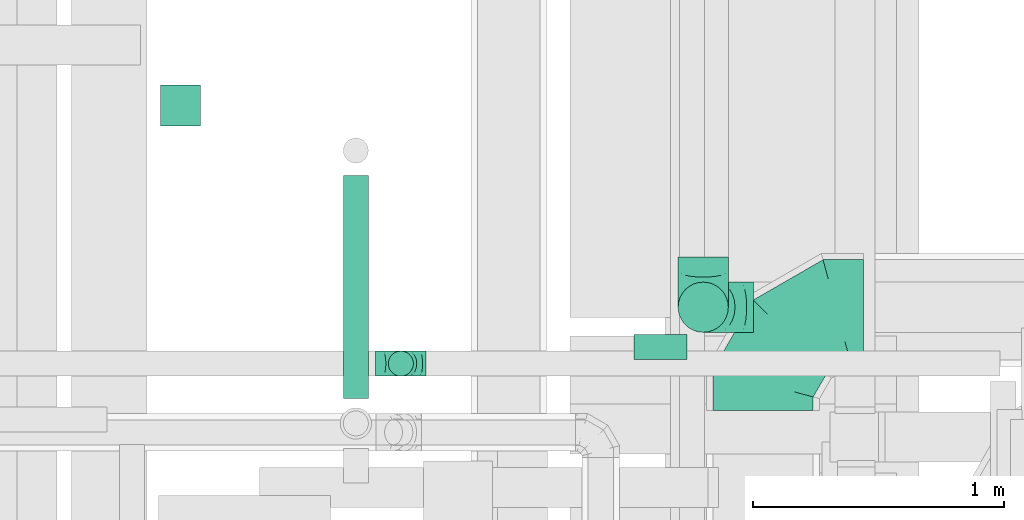
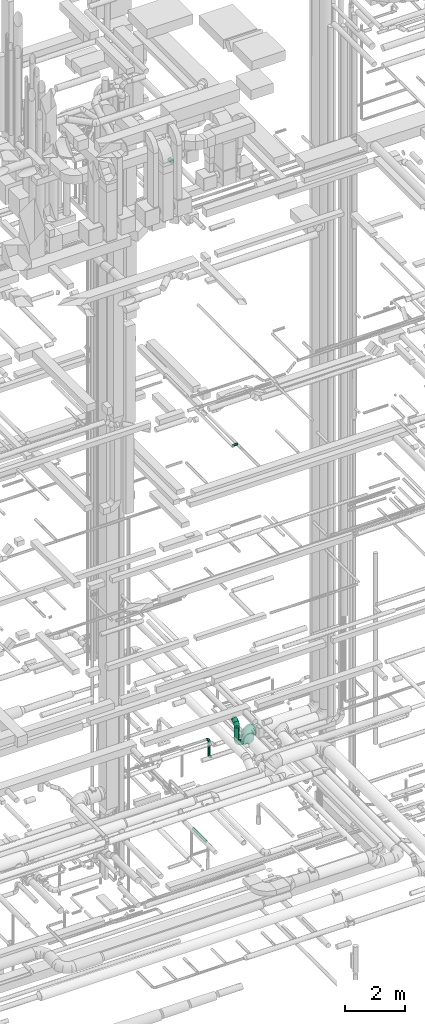
# One storey, part 267 of 337: 5 flow fittings, 5 flow segments.
"""IFC2X3 building model written with IfcOpenShell, lengths in millimetres."""

from ifc_helpers import new_model, entity, si_unit, converted_unit, derived_unit, direction, frame, origin, origin_2d_with_axis, place, context, subcontext, project, spatial, circle, extrude, faceted_brep, source, transform, mapped, material, type_object, type_shapes, element, save


model = new_model("IFC2X3")

# Units and contexts
model_context = context("Model", 3, precision=0.01, world=origin(), true_north=direction((6.12303176911189e-17, 1.0)))
body_context = subcontext(model_context, "Body", "Model", "MODEL_VIEW")
ifc_project = project(units=[si_unit("LENGTHUNIT", "METRE", prefix="MILLI"), si_unit("AREAUNIT", "SQUARE_METRE"), si_unit("VOLUMEUNIT", "CUBIC_METRE"), converted_unit("PLANEANGLEUNIT", "DEGREE", entity("IfcRatioMeasure", 0.0174532925199433), si_unit("PLANEANGLEUNIT", "RADIAN"), dimensions=[0, 0, 0, 0, 0, 0, 0]), si_unit("MASSUNIT", "GRAM", prefix="KILO"), derived_unit("MASSDENSITYUNIT", [(si_unit("MASSUNIT", "GRAM", prefix="KILO"), 1), (si_unit("LENGTHUNIT", "METRE"), -3)]), derived_unit("MOMENTOFINERTIAUNIT", [(si_unit("LENGTHUNIT", "METRE"), 4)]), si_unit("TIMEUNIT", "SECOND"), si_unit("FREQUENCYUNIT", "HERTZ"), si_unit("THERMODYNAMICTEMPERATUREUNIT", "DEGREE_CELSIUS"), derived_unit("THERMALTRANSMITTANCEUNIT", [(si_unit("MASSUNIT", "GRAM", prefix="KILO"), 1), (si_unit("THERMODYNAMICTEMPERATUREUNIT", "KELVIN"), -1), (si_unit("TIMEUNIT", "SECOND"), -3)]), derived_unit("VOLUMETRICFLOWRATEUNIT", [(si_unit("LENGTHUNIT", "METRE"), 3), (si_unit("TIMEUNIT", "SECOND"), -1)]), derived_unit("MASSFLOWRATEUNIT", [(si_unit("MASSUNIT", "GRAM", prefix="KILO"), 1), (si_unit("TIMEUNIT", "SECOND"), -1)]), derived_unit("ROTATIONALFREQUENCYUNIT", [(si_unit("TIMEUNIT", "SECOND"), -1)]), si_unit("ELECTRICCURRENTUNIT", "AMPERE"), si_unit("ELECTRICVOLTAGEUNIT", "VOLT"), si_unit("POWERUNIT", "WATT"), si_unit("FORCEUNIT", "NEWTON", prefix="KILO"), si_unit("ILLUMINANCEUNIT", "LUX"), si_unit("LUMINOUSFLUXUNIT", "LUMEN"), si_unit("LUMINOUSINTENSITYUNIT", "CANDELA"), derived_unit("USERDEFINED", [(si_unit("MASSUNIT", "GRAM", prefix="KILO"), -1), (si_unit("LENGTHUNIT", "METRE"), -2), (si_unit("TIMEUNIT", "SECOND"), 3), (si_unit("LUMINOUSFLUXUNIT", "LUMEN"), 1)]), derived_unit("LINEARVELOCITYUNIT", [(si_unit("LENGTHUNIT", "METRE"), 1), (si_unit("TIMEUNIT", "SECOND"), -1)]), si_unit("PRESSUREUNIT", "PASCAL"), derived_unit("USERDEFINED", [(si_unit("LENGTHUNIT", "METRE"), -2), (si_unit("MASSUNIT", "GRAM", prefix="KILO"), 1), (si_unit("TIMEUNIT", "SECOND"), -2)]), derived_unit("LINEARFORCEUNIT", [(si_unit("MASSUNIT", "GRAM", prefix="KILO"), 1), (si_unit("LENGTHUNIT", "METRE"), 1), (si_unit("TIMEUNIT", "SECOND"), -2), (si_unit("LENGTHUNIT", "METRE"), -1)]), derived_unit("PLANARFORCEUNIT", [(si_unit("MASSUNIT", "GRAM", prefix="KILO"), 1), (si_unit("LENGTHUNIT", "METRE"), 1), (si_unit("TIMEUNIT", "SECOND"), -2), (si_unit("LENGTHUNIT", "METRE"), -2)])], contexts=[model_context])

# Site, building, storey
site_placement = place(None, origin())
site = spatial("IfcSite", under=ifc_project, at=site_placement, CompositionType="ELEMENT")
building_placement = place(site_placement, origin())
building = spatial("IfcBuilding", under=site, at=building_placement, CompositionType="ELEMENT")
storey_placement = place(building_placement, origin())
storey = spatial("IfcBuildingStorey", under=building, at=storey_placement, CompositionType="ELEMENT", Elevation=0.0)

# Flow segments
duct_segment_type = type_object("IfcDuctSegmentType", PredefinedType="NOTDEFINED")
flow_segment_1_placement = place(storey_placement, frame((62974.94, 11897.88, -651.6)))
element("IfcFlowSegment", 1, at=flow_segment_1_placement, inside=storey, type_object=duct_segment_type, context=body_context, shape_type="SweptSolid", body=[
    extrude(circle(Radius=50.0, at=origin_2d_with_axis()), frame((51.6, 0.0, 51.6), z_axis=(0.0, 1.0, 0.0), x_axis=(1.0, 0.0, 0.0)), (0.0, 0.0, 1.0), 886.783699999998),
])
flow_segment_2_placement = place(storey_placement, frame((64135.03, 12051.29, 14998.4)))
element("IfcFlowSegment", 2, at=flow_segment_2_placement, inside=storey, type_object=duct_segment_type, context=body_context, shape_type="SweptSolid", body=[
    extrude(circle(Radius=50.0, at=origin_2d_with_axis()), frame((0.0, 51.6, 51.6), z_axis=(1.0, 0.0, 0.0), x_axis=(0.0, 1.0, 0.0)), (0.0, 0.0, 1.0), 209.999999999987),
])
flow_segment_3_placement = place(storey_placement, frame((62247.25, 12983.12, 26668.4)))
element("IfcFlowSegment", 3, at=flow_segment_3_placement, inside=storey, type_object=duct_segment_type, context=body_context, shape_type="SweptSolid", body=[
    extrude(circle(Radius=80.0, at=origin_2d_with_axis()), frame((81.6, 0.0, 81.6), z_axis=(0.0, 1.0, 0.0), x_axis=(-1.0, 0.0, 0.0)), (0.0, 0.0, 1.0), 162.499999999996),
])
flow_segment_4_placement = place(storey_placement, frame((64308.55, 12159.21, 2900.0)))
element("IfcFlowSegment", 4, at=flow_segment_4_placement, inside=storey, type_object=duct_segment_type, context=body_context, shape_type="SweptSolid", body=[
    extrude(circle(Radius=100.0, at=origin_2d_with_axis()), frame((101.6, 101.6, 0.0), z_axis=(0.0, 0.0, 1.0), x_axis=(0.0, -1.0, 0.0)), (0.0, 0.0, 1.0), 500.000000000008),
])
flow_segment_5_placement = place(storey_placement, frame((63154.26, 11984.54, 2800.0)))
element("IfcFlowSegment", 5, at=flow_segment_5_placement, inside=storey, type_object=duct_segment_type, context=body_context, shape_type="SweptSolid", body=[
    extrude(circle(Radius=50.0, at=origin_2d_with_axis()), frame((51.6, 51.6, 0.0), z_axis=(0.0, 0.0, 1.0), x_axis=(0.0, 1.0, 0.0)), (0.0, 0.0, 1.0), 549.99999999997),
])

# Flow fittings
ifc_material = material()
duct_fitting_type_1 = type_object("IfcDuctFittingType", PredefinedType="NOTDEFINED", material=ifc_material)
shared_shape_1 = source(origin(), body_context, "Body", "Brep", [
    faceted_brep([(-100.0, 0.0, -50.0), (-100.0, -12.94, -48.3), (-100.0, -25.0, -43.3), (-100.0, -35.36, -35.36), (-100.0, -43.3, -25.0), (-100.0, -48.3, -12.94), (-100.0, -50.0, 0.0), (-100.0, -48.3, 12.94), (-100.0, -43.3, 25.0), (-100.0, -35.36, 35.36), (-100.0, -25.0, 43.3), (-100.0, -12.94, 48.3), (-100.0, 0.0, 50.0), (-100.0, 12.94, 48.3), (-100.0, 25.0, 43.3), (-100.0, 35.36, 35.36), (-100.0, 43.3, 25.0), (-100.0, 48.3, 12.94), (-100.0, 50.0, 0.0), (-100.0, 48.3, -12.94), (-100.0, 43.3, -25.0), (-100.0, 35.36, -35.36), (-100.0, 25.0, -43.3), (-100.0, 12.94, -48.3), (-76.67, 12.94, 48.3), (-79.9, 25.0, 43.3), (-73.21, 0.0, 50.0), (-82.68, 35.36, 35.36), (-86.15, 48.3, 12.94), (-86.6, 50.0, 0.0), (-84.81, 43.3, 25.0), (-84.81, 43.3, -25.0), (-82.68, 35.36, -35.36), (-86.15, 48.3, -12.94), (-76.67, 12.94, -48.3), (-73.21, 0.0, -50.0), (-79.9, 25.0, -43.3), (-69.74, -12.94, -48.3), (-66.51, -25.0, -43.3), (-63.73, -35.36, -35.36), (-61.6, -43.3, -25.0), (-60.26, -48.3, -12.94), (-59.81, -50.0, 0.0), (-60.26, -48.3, 12.94), (-61.6, -43.3, 25.0), (-63.73, -35.36, 35.36), (-66.51, -25.0, 43.3), (-69.74, -12.94, 48.3), (-36.27, 36.27, 48.3), (-45.1, 45.1, 43.3), (-26.79, 26.79, 50.0), (-52.68, 52.68, 35.36), (-58.49, 58.49, 25.0), (-62.15, 62.15, 12.94), (-63.4, 63.4, 0.0), (-62.15, 62.15, -12.94), (-58.49, 58.49, -25.0), (-52.68, 52.68, -35.36), (-36.27, 36.27, -48.3), (-26.79, 26.79, -50.0), (-45.1, 45.1, -43.3), (-17.32, 17.32, -48.3), (-8.49, 8.49, -43.3), (-0.91, 0.91, -35.36), (4.9, -4.9, -25.0), (8.56, -8.56, -12.94), (9.81, -9.81, 0.0), (8.56, -8.56, 12.94), (4.9, -4.9, 25.0), (-0.91, 0.91, 35.36), (-8.49, 8.49, 43.3), (-17.32, 17.32, 48.3), (-12.94, 76.67, 48.3), (-25.0, 79.9, 43.3), (0.0, 73.21, 50.0), (-35.36, 82.68, 35.36), (-43.3, 84.81, 25.0), (-48.3, 86.15, 12.94), (-50.0, 86.6, 0.0), (-48.3, 86.15, -12.94), (-43.3, 84.81, -25.0), (-35.36, 82.68, -35.36), (-12.94, 76.67, -48.3), (0.0, 73.21, -50.0), (-25.0, 79.9, -43.3), (12.94, 69.74, -48.3), (25.0, 66.51, -43.3), (35.36, 63.73, -35.36), (43.3, 61.6, -25.0), (48.3, 60.26, -12.94), (50.0, 59.81, 0.0), (48.3, 60.26, 12.94), (43.3, 61.6, 25.0), (35.36, 63.73, 35.36), (25.0, 66.51, 43.3), (12.94, 69.74, 48.3), (-12.94, 100.0, -48.3), (-25.0, 100.0, -43.3), (-35.36, 100.0, -35.36), (-43.3, 100.0, -25.0), (-48.3, 100.0, -12.94), (-50.0, 100.0, 0.0), (-48.3, 100.0, 12.94), (-43.3, 100.0, 25.0), (-35.36, 100.0, 35.36), (-25.0, 100.0, 43.3), (-12.94, 100.0, 48.3), (0.0, 100.0, 50.0), (12.94, 100.0, 48.3), (25.0, 100.0, 43.3), (35.36, 100.0, 35.36), (43.3, 100.0, 25.0), (48.3, 100.0, 12.94), (50.0, 100.0, 0.0), (48.3, 100.0, -12.94), (43.3, 100.0, -25.0), (35.36, 100.0, -35.36), (25.0, 100.0, -43.3), (12.94, 100.0, -48.3), (0.0, 100.0, -50.0)], [[[0, 1, 2, 3, 4, 5, 6, 7, 8, 9, 10, 11, 12, 13, 14, 15, 16, 17, 18, 19, 20, 21, 22, 23]], [[24, 25, 14, 13]], [[26, 24, 13, 12]], [[14, 25, 27, 15]], [[28, 29, 18, 17]], [[30, 28, 17, 16]], [[15, 27, 30, 16]], [[20, 31, 32, 21]], [[33, 31, 20, 19]], [[18, 29, 33, 19]], [[34, 35, 0, 23]], [[36, 34, 23, 22]], [[32, 36, 22, 21]], [[2, 1, 37, 38]], [[3, 2, 38, 39]], [[0, 35, 37, 1]], [[5, 4, 40, 41]], [[6, 5, 41, 42]], [[3, 39, 40, 4]], [[6, 42, 43, 7]], [[7, 43, 44, 8]], [[8, 44, 45, 9]], [[10, 46, 47, 11]], [[11, 47, 26, 12]], [[10, 9, 45, 46]], [[48, 49, 25, 24]], [[50, 48, 24, 26]], [[27, 25, 49, 51]], [[52, 53, 28, 30]], [[51, 52, 30, 27]], [[29, 28, 53, 54]], [[55, 56, 31, 33]], [[54, 55, 33, 29]], [[57, 32, 31, 56]], [[58, 59, 35, 34]], [[60, 58, 34, 36]], [[57, 60, 36, 32]], [[37, 35, 59, 61]], [[38, 37, 61, 62]], [[39, 38, 62, 63]], [[41, 40, 64, 65]], [[42, 41, 65, 66]], [[63, 64, 40, 39]], [[43, 42, 66, 67]], [[44, 43, 67, 68]], [[68, 69, 45, 44]], [[46, 45, 69, 70]], [[47, 46, 70, 71]], [[26, 47, 71, 50]], [[72, 73, 49, 48]], [[74, 72, 48, 50]], [[51, 49, 73, 75]], [[76, 77, 53, 52]], [[75, 76, 52, 51]], [[54, 53, 77, 78]], [[79, 80, 56, 55]], [[78, 79, 55, 54]], [[81, 57, 56, 80]], [[82, 83, 59, 58]], [[84, 82, 58, 60]], [[81, 84, 60, 57]], [[61, 59, 83, 85]], [[62, 61, 85, 86]], [[63, 62, 86, 87]], [[65, 64, 88, 89]], [[66, 65, 89, 90]], [[87, 88, 64, 63]], [[67, 66, 90, 91]], [[68, 67, 91, 92]], [[92, 93, 69, 68]], [[70, 69, 93, 94]], [[71, 70, 94, 95]], [[50, 71, 95, 74]], [[96, 97, 98, 99, 100, 101, 102, 103, 104, 105, 106, 107, 108, 109, 110, 111, 112, 113, 114, 115, 116, 117, 118, 119]], [[72, 74, 107, 106]], [[73, 72, 106, 105]], [[75, 73, 105, 104]], [[77, 76, 103, 102]], [[78, 77, 102, 101]], [[75, 104, 103, 76]], [[78, 101, 100, 79]], [[79, 100, 99, 80]], [[80, 99, 98, 81]], [[96, 119, 83, 82]], [[97, 96, 82, 84]], [[84, 81, 98, 97]], [[83, 119, 118, 85]], [[85, 118, 117, 86]], [[86, 117, 116, 87]], [[88, 115, 114, 89]], [[89, 114, 113, 90]], [[87, 116, 115, 88]], [[91, 90, 113, 112]], [[92, 91, 112, 111]], [[93, 92, 111, 110]], [[95, 94, 109, 108]], [[74, 95, 108, 107]], [[110, 109, 94, 93]]]),
])
type_shapes(duct_fitting_type_1, [shared_shape_1])
for number, where, z_axis, x_axis in (
    (6, (63205.86, 12036.14, 3450.0), (0.0, 1.0, 0.0), (1.0, 0.0, 0.0)),
    (7, (63205.86, 12036.14, 2700.0), (0.0, -1.0, 0.0), (0.0, 0.0, -1.0)),
):
    element("IfcFlowFitting", number, at=place(storey_placement, frame(where, z_axis=z_axis, x_axis=x_axis)), inside=storey, type_object=duct_fitting_type_1, material=ifc_material, context=body_context, shape_type="MappedRepresentation", body=[
        mapped(shared_shape_1, transform((0.0, 0.0, 0.0), scale=1.0)),
    ])
duct_fitting_type_2 = type_object("IfcDuctFittingType", PredefinedType="NOTDEFINED", material=ifc_material)
shared_shape_2 = source(origin(), body_context, "Body", "Brep", [
    faceted_brep([(-200.0, 0.0, -100.0), (-200.0, -25.88, -96.59), (-200.0, -50.0, -86.6), (-200.0, -70.71, -70.71), (-200.0, -86.6, -50.0), (-200.0, -96.59, -25.88), (-200.0, -100.0, 0.0), (-200.0, -96.59, 25.88), (-200.0, -86.6, 50.0), (-200.0, -70.71, 70.71), (-200.0, -50.0, 86.6), (-200.0, -25.88, 96.59), (-200.0, 0.0, 100.0), (-200.0, 25.88, 96.59), (-200.0, 50.0, 86.6), (-200.0, 70.71, 70.71), (-200.0, 86.6, 50.0), (-200.0, 96.59, 25.88), (-200.0, 100.0, 0.0), (-200.0, 96.59, -25.88), (-200.0, 86.6, -50.0), (-200.0, 70.71, -70.71), (-200.0, 50.0, -86.6), (-200.0, 25.88, -96.59), (-153.35, 25.88, 96.59), (-159.81, 50.0, 86.6), (-146.41, 0.0, 100.0), (-165.36, 70.71, 70.71), (-172.29, 96.59, 25.88), (-173.21, 100.0, 0.0), (-169.62, 86.6, 50.0), (-169.62, 86.6, -50.0), (-165.36, 70.71, -70.71), (-172.29, 96.59, -25.88), (-153.35, 25.88, -96.59), (-146.41, 0.0, -100.0), (-159.81, 50.0, -86.6), (-139.48, -25.88, -96.59), (-133.01, -50.0, -86.6), (-127.46, -70.71, -70.71), (-123.21, -86.6, -50.0), (-120.53, -96.59, -25.88), (-119.62, -100.0, 0.0), (-120.53, -96.59, 25.88), (-123.21, -86.6, 50.0), (-127.46, -70.71, 70.71), (-133.01, -50.0, 86.6), (-139.48, -25.88, 96.59), (-72.54, 72.54, 96.59), (-90.19, 90.19, 86.6), (-53.59, 53.59, 100.0), (-105.35, 105.35, 70.71), (-116.99, 116.99, 50.0), (-124.3, 124.3, 25.88), (-126.79, 126.79, 0.0), (-124.3, 124.3, -25.88), (-116.99, 116.99, -50.0), (-105.35, 105.35, -70.71), (-72.54, 72.54, -96.59), (-53.59, 53.59, -100.0), (-90.19, 90.19, -86.6), (-34.64, 34.64, -96.59), (-16.99, 16.99, -86.6), (-1.83, 1.83, -70.71), (9.81, -9.81, -50.0), (17.12, -17.12, -25.88), (19.62, -19.62, 0.0), (17.12, -17.12, 25.88), (9.81, -9.81, 50.0), (-1.83, 1.83, 70.71), (-16.99, 16.99, 86.6), (-34.64, 34.64, 96.59), (-25.88, 153.35, 96.59), (-50.0, 159.81, 86.6), (0.0, 146.41, 100.0), (-70.71, 165.36, 70.71), (-86.6, 169.62, 50.0), (-96.59, 172.29, 25.88), (-100.0, 173.21, 0.0), (-96.59, 172.29, -25.88), (-86.6, 169.62, -50.0), (-70.71, 165.36, -70.71), (-25.88, 153.35, -96.59), (0.0, 146.41, -100.0), (-50.0, 159.81, -86.6), (25.88, 139.48, -96.59), (50.0, 133.01, -86.6), (70.71, 127.46, -70.71), (86.6, 123.21, -50.0), (96.59, 120.53, -25.88), (100.0, 119.62, 0.0), (96.59, 120.53, 25.88), (86.6, 123.21, 50.0), (70.71, 127.46, 70.71), (50.0, 133.01, 86.6), (25.88, 139.48, 96.59), (-25.88, 200.0, -96.59), (-50.0, 200.0, -86.6), (-70.71, 200.0, -70.71), (-86.6, 200.0, -50.0), (-96.59, 200.0, -25.88), (-100.0, 200.0, 0.0), (-96.59, 200.0, 25.88), (-86.6, 200.0, 50.0), (-70.71, 200.0, 70.71), (-50.0, 200.0, 86.6), (-25.88, 200.0, 96.59), (0.0, 200.0, 100.0), (25.88, 200.0, 96.59), (50.0, 200.0, 86.6), (70.71, 200.0, 70.71), (86.6, 200.0, 50.0), (96.59, 200.0, 25.88), (100.0, 200.0, 0.0), (96.59, 200.0, -25.88), (86.6, 200.0, -50.0), (70.71, 200.0, -70.71), (50.0, 200.0, -86.6), (25.88, 200.0, -96.59), (0.0, 200.0, -100.0)], [[[0, 1, 2, 3, 4, 5, 6, 7, 8, 9, 10, 11, 12, 13, 14, 15, 16, 17, 18, 19, 20, 21, 22, 23]], [[24, 25, 14, 13]], [[26, 24, 13, 12]], [[14, 25, 27, 15]], [[28, 29, 18, 17]], [[30, 28, 17, 16]], [[15, 27, 30, 16]], [[20, 31, 32, 21]], [[33, 31, 20, 19]], [[18, 29, 33, 19]], [[34, 35, 0, 23]], [[36, 34, 23, 22]], [[32, 36, 22, 21]], [[1, 0, 35, 37]], [[2, 1, 37, 38]], [[38, 39, 3, 2]], [[5, 4, 40, 41]], [[6, 5, 41, 42]], [[39, 40, 4, 3]], [[6, 42, 43, 7]], [[7, 43, 44, 8]], [[8, 44, 45, 9]], [[9, 45, 46, 10]], [[10, 46, 47, 11]], [[26, 12, 11, 47]], [[48, 49, 25, 24]], [[50, 48, 24, 26]], [[27, 25, 49, 51]], [[52, 53, 28, 30]], [[51, 52, 30, 27]], [[29, 28, 53, 54]], [[55, 56, 31, 33]], [[54, 55, 33, 29]], [[32, 31, 56, 57]], [[58, 59, 35, 34]], [[60, 58, 34, 36]], [[57, 60, 36, 32]], [[37, 35, 59, 61]], [[38, 37, 61, 62]], [[39, 38, 62, 63]], [[41, 40, 64, 65]], [[42, 41, 65, 66]], [[63, 64, 40, 39]], [[43, 42, 66, 67]], [[44, 43, 67, 68]], [[68, 69, 45, 44]], [[46, 45, 69, 70]], [[47, 46, 70, 71]], [[26, 47, 71, 50]], [[72, 73, 49, 48]], [[74, 72, 48, 50]], [[51, 49, 73, 75]], [[76, 77, 53, 52]], [[75, 76, 52, 51]], [[54, 53, 77, 78]], [[79, 80, 56, 55]], [[78, 79, 55, 54]], [[57, 56, 80, 81]], [[82, 83, 59, 58]], [[84, 82, 58, 60]], [[81, 84, 60, 57]], [[61, 59, 83, 85]], [[62, 61, 85, 86]], [[63, 62, 86, 87]], [[65, 64, 88, 89]], [[66, 65, 89, 90]], [[87, 88, 64, 63]], [[67, 66, 90, 91]], [[68, 67, 91, 92]], [[92, 93, 69, 68]], [[70, 69, 93, 94]], [[71, 70, 94, 95]], [[50, 71, 95, 74]], [[96, 97, 98, 99, 100, 101, 102, 103, 104, 105, 106, 107, 108, 109, 110, 111, 112, 113, 114, 115, 116, 117, 118, 119]], [[72, 74, 107, 106]], [[73, 72, 106, 105]], [[75, 73, 105, 104]], [[102, 101, 78, 77]], [[103, 102, 77, 76]], [[75, 104, 103, 76]], [[78, 101, 100, 79]], [[79, 100, 99, 80]], [[80, 99, 98, 81]], [[84, 97, 96, 82]], [[82, 96, 119, 83]], [[84, 81, 98, 97]], [[118, 117, 86, 85]], [[119, 118, 85, 83]], [[116, 87, 86, 117]], [[88, 115, 114, 89]], [[89, 114, 113, 90]], [[115, 88, 87, 116]], [[91, 90, 113, 112]], [[92, 91, 112, 111]], [[111, 110, 93, 92]], [[95, 94, 109, 108]], [[74, 95, 108, 107]], [[110, 109, 94, 93]]]),
])
type_shapes(duct_fitting_type_2, [shared_shape_2])
for number, where, z_axis, x_axis in (
    (8, (64410.14, 12260.8, 3600.0), (1.0, 0.0, 0.0), (0.0, -1.0, 0.0)),
    (9, (64410.14, 12260.8, 2700.0), (0.0, -1.0, 0.0), (0.0, 0.0, -1.0)),
):
    element("IfcFlowFitting", number, at=place(storey_placement, frame(where, z_axis=z_axis, x_axis=x_axis)), inside=storey, type_object=duct_fitting_type_2, material=ifc_material, context=body_context, shape_type="MappedRepresentation", body=[
        mapped(shared_shape_2, transform((0.0, 0.0, 0.0), scale=1.0)),
    ])
duct_fitting_type_3 = type_object("IfcDuctFittingType", PredefinedType="NOTDEFINED", material=ifc_material)
shared_shape_3 = source(origin(), body_context, "Body", "Brep", [
    faceted_brep([(-400.0, 0.0, -200.0), (-400.0, -44.5, -194.99), (-400.0, -86.78, -180.19), (-400.0, -124.7, -156.37), (-400.0, -156.37, -124.7), (-400.0, -180.19, -86.78), (-400.0, -194.99, -44.5), (-400.0, -200.0, 0.0), (-400.0, -194.99, 44.5), (-400.0, -180.19, 86.78), (-400.0, -156.37, 124.7), (-400.0, -124.7, 156.37), (-400.0, -86.78, 180.19), (-400.0, -44.5, 194.99), (-400.0, 0.0, 200.0), (-400.0, 44.5, 194.99), (-400.0, 86.78, 180.19), (-400.0, 124.7, 156.37), (-400.0, 156.37, 124.7), (-400.0, 180.19, 86.78), (-400.0, 194.99, 44.5), (-400.0, 200.0, 0.0), (-400.0, 194.99, -44.5), (-400.0, 180.19, -86.78), (-400.0, 156.37, -124.7), (-400.0, 124.7, -156.37), (-400.0, 86.78, -180.19), (-400.0, 44.5, -194.99), (-292.82, 0.0, 200.0), (-304.75, 44.5, 194.99), (-316.07, 86.78, 180.19), (-326.23, 124.7, 156.37), (-334.72, 156.37, 124.7), (-341.1, 180.19, 86.78), (-345.07, 194.99, 44.5), (-346.41, 200.0, 0.0), (-345.07, 194.99, -44.5), (-341.1, 180.19, -86.78), (-334.72, 156.37, -124.7), (-326.23, 124.7, -156.37), (-316.07, 86.78, -180.19), (-304.75, 44.5, -194.99), (-292.82, 0.0, -200.0), (-280.9, -44.5, -194.99), (-269.57, -86.78, -180.19), (-259.41, -124.7, -156.37), (-250.92, -156.37, -124.7), (-244.54, -180.19, -86.78), (-240.57, -194.99, -44.5), (-239.23, -200.0, 0.0), (-240.57, -194.99, 44.5), (-244.54, -180.19, 86.78), (-250.92, -156.37, 124.7), (-259.41, -124.7, 156.37), (-269.57, -86.78, 180.19), (-280.9, -44.5, 194.99), (-107.18, 107.18, 200.0), (-139.76, 139.76, 194.99), (-170.7, 170.7, 180.19), (-198.46, 198.46, 156.37), (-221.65, 221.65, 124.7), (-239.09, 239.09, 86.78), (-249.92, 249.92, 44.5), (-253.59, 253.59, 0.0), (-249.92, 249.92, -44.5), (-239.09, 239.09, -86.78), (-221.65, 221.65, -124.7), (-198.46, 198.46, -156.37), (-170.7, 170.7, -180.19), (-139.76, 139.76, -194.99), (-107.18, 107.18, -200.0), (-74.6, 74.6, -194.99), (-43.65, 43.65, -180.19), (-15.89, 15.89, -156.37), (7.29, -7.29, -124.7), (24.73, -24.73, -86.78), (35.56, -35.56, -44.5), (39.23, -39.23, 0.0), (35.56, -35.56, 44.5), (24.73, -24.73, 86.78), (7.29, -7.29, 124.7), (-15.89, 15.89, 156.37), (-43.65, 43.65, 180.19), (-74.6, 74.6, 194.99), (0.0, 292.82, 200.0), (-44.5, 304.75, 194.99), (-86.78, 316.07, 180.19), (-124.7, 326.23, 156.37), (-156.37, 334.72, 124.7), (-180.19, 341.1, 86.78), (-194.99, 345.07, 44.5), (-200.0, 346.41, 0.0), (-194.99, 345.07, -44.5), (-180.19, 341.1, -86.78), (-156.37, 334.72, -124.7), (-124.7, 326.23, -156.37), (-86.78, 316.07, -180.19), (-44.5, 304.75, -194.99), (0.0, 292.82, -200.0), (44.5, 280.9, -194.99), (86.78, 269.57, -180.19), (124.7, 259.41, -156.37), (156.37, 250.92, -124.7), (180.19, 244.54, -86.78), (194.99, 240.57, -44.5), (200.0, 239.23, 0.0), (194.99, 240.57, 44.5), (180.19, 244.54, 86.78), (156.37, 250.92, 124.7), (124.7, 259.41, 156.37), (86.78, 269.57, 180.19), (44.5, 280.9, 194.99), (-44.5, 400.0, -194.99), (-86.78, 400.0, -180.19), (-124.7, 400.0, -156.37), (-156.37, 400.0, -124.7), (-180.19, 400.0, -86.78), (-194.99, 400.0, -44.5), (-200.0, 400.0, 0.0), (-194.99, 400.0, 44.5), (-180.19, 400.0, 86.78), (-156.37, 400.0, 124.7), (-124.7, 400.0, 156.37), (-86.78, 400.0, 180.19), (-44.5, 400.0, 194.99), (0.0, 400.0, 200.0), (44.5, 400.0, 194.99), (86.78, 400.0, 180.19), (124.7, 400.0, 156.37), (156.37, 400.0, 124.7), (180.19, 400.0, 86.78), (194.99, 400.0, 44.5), (200.0, 400.0, 0.0), (194.99, 400.0, -44.5), (180.19, 400.0, -86.78), (156.37, 400.0, -124.7), (124.7, 400.0, -156.37), (86.78, 400.0, -180.19), (44.5, 400.0, -194.99), (0.0, 400.0, -200.0)], [[[0, 1, 2, 3, 4, 5, 6, 7, 8, 9, 10, 11, 12, 13, 14, 15, 16, 17, 18, 19, 20, 21, 22, 23, 24, 25, 26, 27]], [[28, 29, 15, 14]], [[30, 31, 17, 16]], [[29, 30, 16, 15]], [[31, 32, 18, 17]], [[32, 33, 19, 18]], [[34, 35, 21, 20]], [[33, 34, 20, 19]], [[35, 36, 22, 21]], [[37, 38, 24, 23]], [[36, 37, 23, 22]], [[38, 39, 25, 24]], [[39, 40, 26, 25]], [[41, 42, 0, 27]], [[40, 41, 27, 26]], [[1, 0, 42, 43]], [[43, 44, 2, 1]], [[45, 3, 2, 44]], [[45, 46, 4, 3]], [[5, 4, 46, 47]], [[47, 48, 6, 5]], [[49, 7, 6, 48]], [[7, 49, 50, 8]], [[8, 50, 51, 9]], [[9, 51, 52, 10]], [[52, 53, 11, 10]], [[11, 53, 54, 12]], [[12, 54, 55, 13]], [[13, 55, 28, 14]], [[56, 57, 29, 28]], [[58, 59, 31, 30]], [[57, 58, 30, 29]], [[59, 60, 32, 31]], [[60, 61, 33, 32]], [[62, 63, 35, 34]], [[61, 62, 34, 33]], [[63, 64, 36, 35]], [[65, 66, 38, 37]], [[64, 65, 37, 36]], [[66, 67, 39, 38]], [[67, 68, 40, 39]], [[69, 70, 42, 41]], [[68, 69, 41, 40]], [[43, 42, 70, 71]], [[71, 72, 44, 43]], [[73, 45, 44, 72]], [[73, 74, 46, 45]], [[47, 46, 74, 75]], [[75, 76, 48, 47]], [[77, 49, 48, 76]], [[50, 49, 77, 78]], [[51, 50, 78, 79]], [[52, 51, 79, 80]], [[80, 81, 53, 52]], [[54, 53, 81, 82]], [[55, 54, 82, 83]], [[28, 55, 83, 56]], [[84, 85, 57, 56]], [[86, 87, 59, 58]], [[85, 86, 58, 57]], [[87, 88, 60, 59]], [[88, 89, 61, 60]], [[90, 91, 63, 62]], [[89, 90, 62, 61]], [[91, 92, 64, 63]], [[93, 94, 66, 65]], [[92, 93, 65, 64]], [[94, 95, 67, 66]], [[95, 96, 68, 67]], [[97, 98, 70, 69]], [[96, 97, 69, 68]], [[71, 70, 98, 99]], [[99, 100, 72, 71]], [[101, 73, 72, 100]], [[101, 102, 74, 73]], [[75, 74, 102, 103]], [[103, 104, 76, 75]], [[105, 77, 76, 104]], [[78, 77, 105, 106]], [[79, 78, 106, 107]], [[80, 79, 107, 108]], [[108, 109, 81, 80]], [[82, 81, 109, 110]], [[83, 82, 110, 111]], [[56, 83, 111, 84]], [[112, 113, 114, 115, 116, 117, 118, 119, 120, 121, 122, 123, 124, 125, 126, 127, 128, 129, 130, 131, 132, 133, 134, 135, 136, 137, 138, 139]], [[85, 84, 125, 124]], [[86, 85, 124, 123]], [[87, 86, 123, 122]], [[122, 121, 88, 87]], [[89, 88, 121, 120]], [[90, 89, 120, 119]], [[91, 90, 119, 118]], [[91, 118, 117, 92]], [[92, 117, 116, 93]], [[93, 116, 115, 94]], [[115, 114, 95, 94]], [[95, 114, 113, 96]], [[96, 113, 112, 97]], [[97, 112, 139, 98]], [[98, 139, 138, 99]], [[99, 138, 137, 100]], [[100, 137, 136, 101]], [[136, 135, 102, 101]], [[102, 135, 134, 103]], [[103, 134, 133, 104]], [[104, 133, 132, 105]], [[106, 105, 132, 131]], [[107, 106, 131, 130]], [[108, 107, 130, 129]], [[129, 128, 109, 108]], [[110, 109, 128, 127]], [[111, 110, 127, 126]], [[84, 111, 126, 125]]]),
])
type_shapes(duct_fitting_type_3, [shared_shape_3])
flow_fitting_placement = place(storey_placement, frame((64648.27, 12249.91, 3050.0), z_axis=(0.0, 0.0, 1.0), x_axis=(-1.0, 0.0, 0.0)))
element("IfcFlowFitting", 10, at=flow_fitting_placement, inside=storey, type_object=duct_fitting_type_3, material=ifc_material, context=body_context, shape_type="MappedRepresentation", body=[
    mapped(shared_shape_3, transform((0.0, 0.0, 0.0), scale=1.0)),
])

save(model, "model.ifc")
